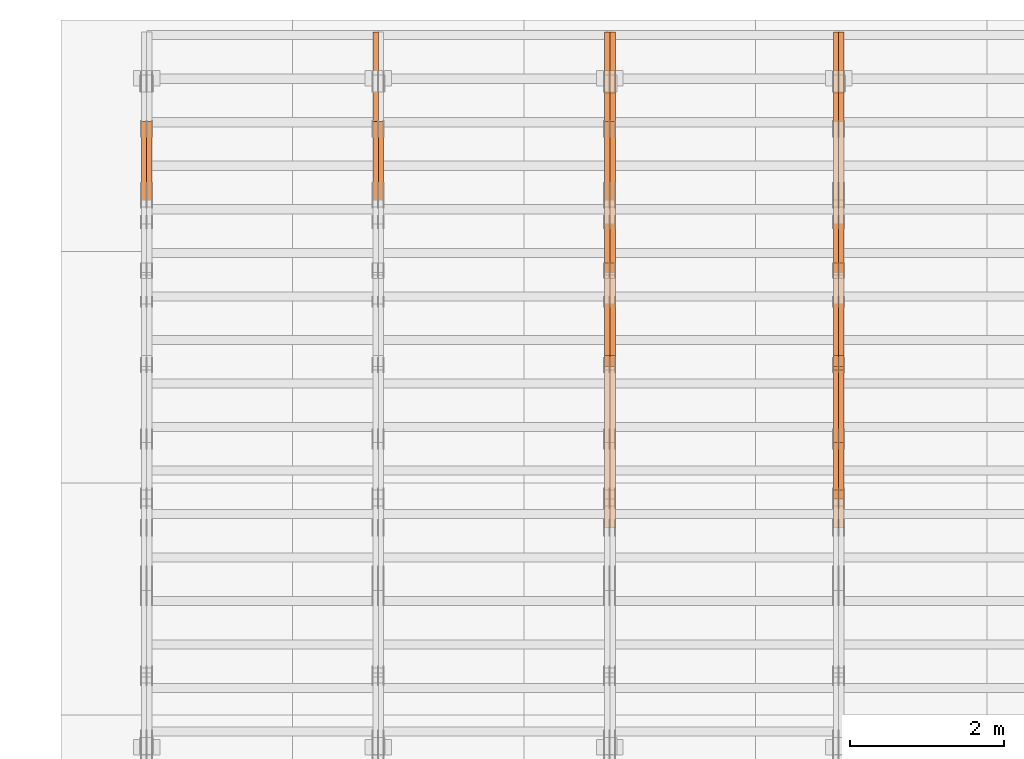
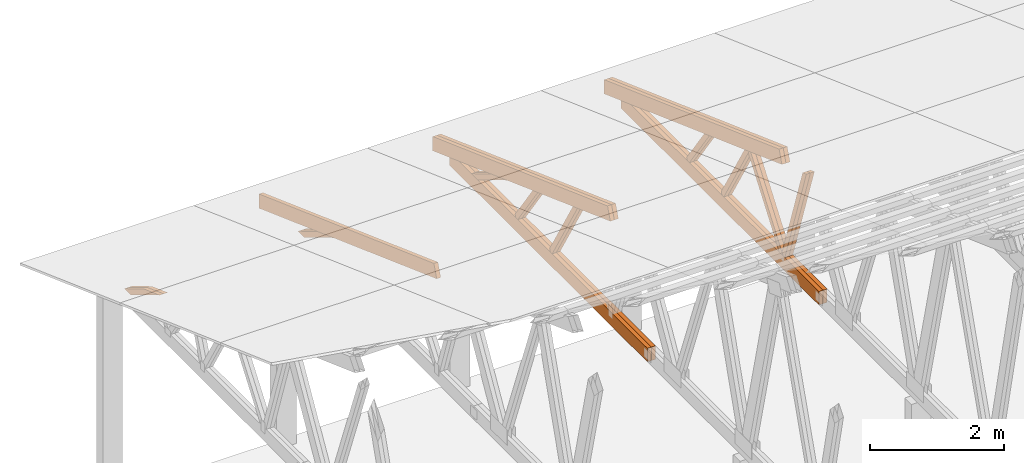
# One storey, part 36 of 189: 27 proxies.
"""IFC2X3 building model written with IfcOpenShell, lengths in millimetres."""

from ifc_helpers import new_model, entity, si_unit, converted_unit, derived_unit, direction, frame, origin, place, context, subcontext, project, spatial, polyline, outline, extrude, source, transform, mapped, material, type_object, type_shapes, element, save


model = new_model("IFC2X3")

# Units and contexts
model_context = context("Model", 3, precision=0.01, world=origin(), true_north=direction((6.12303176911189e-17, 1.0)))
body_context = subcontext(model_context, "Body", "Model", "MODEL_VIEW")
ifc_project = project(units=[si_unit("LENGTHUNIT", "METRE", prefix="MILLI"), si_unit("AREAUNIT", "SQUARE_METRE"), si_unit("VOLUMEUNIT", "CUBIC_METRE"), converted_unit("PLANEANGLEUNIT", "DEGREE", entity("IfcRatioMeasure", 0.0174532925199433), si_unit("PLANEANGLEUNIT", "RADIAN"), dimensions=[0, 0, 0, 0, 0, 0, 0]), si_unit("MASSUNIT", "GRAM", prefix="KILO"), derived_unit("MASSDENSITYUNIT", [(si_unit("MASSUNIT", "GRAM", prefix="KILO"), 1), (si_unit("LENGTHUNIT", "METRE"), -3)]), si_unit("TIMEUNIT", "SECOND"), si_unit("FREQUENCYUNIT", "HERTZ"), si_unit("THERMODYNAMICTEMPERATUREUNIT", "DEGREE_CELSIUS"), derived_unit("THERMALTRANSMITTANCEUNIT", [(si_unit("MASSUNIT", "GRAM", prefix="KILO"), 1), (si_unit("THERMODYNAMICTEMPERATUREUNIT", "KELVIN"), -1), (si_unit("TIMEUNIT", "SECOND"), -3)]), derived_unit("VOLUMETRICFLOWRATEUNIT", [(si_unit("LENGTHUNIT", "METRE"), 3), (si_unit("TIMEUNIT", "SECOND"), -1)]), si_unit("ELECTRICCURRENTUNIT", "AMPERE"), si_unit("ELECTRICVOLTAGEUNIT", "VOLT"), si_unit("POWERUNIT", "WATT"), si_unit("FORCEUNIT", "NEWTON"), si_unit("ILLUMINANCEUNIT", "LUX"), si_unit("LUMINOUSFLUXUNIT", "LUMEN"), si_unit("LUMINOUSINTENSITYUNIT", "CANDELA"), derived_unit("USERDEFINED", [(si_unit("MASSUNIT", "GRAM", prefix="KILO"), -1), (si_unit("LENGTHUNIT", "METRE"), -2), (si_unit("TIMEUNIT", "SECOND"), 3), (si_unit("LUMINOUSFLUXUNIT", "LUMEN"), 1)]), derived_unit("LINEARVELOCITYUNIT", [(si_unit("LENGTHUNIT", "METRE"), 1), (si_unit("TIMEUNIT", "SECOND"), -1)]), si_unit("PRESSUREUNIT", "PASCAL"), derived_unit("USERDEFINED", [(si_unit("LENGTHUNIT", "METRE"), -2), (si_unit("MASSUNIT", "GRAM", prefix="KILO"), 1), (si_unit("TIMEUNIT", "SECOND"), -2)])], contexts=[model_context])

# Site, building, storey
site_placement = place(None, origin())
site = spatial("IfcSite", under=ifc_project, at=site_placement, CompositionType="ELEMENT")
building_placement = place(site_placement, origin())
building = spatial("IfcBuilding", under=site, at=building_placement, CompositionType="ELEMENT")
storey_placement = place(building_placement, origin())
storey = spatial("IfcBuildingStorey", under=building, at=storey_placement, Name="Default", CompositionType="ELEMENT", Elevation=0.0)

# Proxies
ifc_material_1 = material(Name="IfcSurfaceStyle #50600")
building_element_proxy_type_1 = type_object("IfcBuildingElementProxyType", Name="T1-W9 50598", PredefinedType="NOTDEFINED", material=ifc_material_1)
shared_shape_1 = source(origin(), body_context, "Body", "SweptSolid", [
    extrude(outline(polyline([(-1151.44310138162, -47.5000079487596), (776.329826327547, -47.5000079487596), (809.267611644053, -8.1966354137375e-07), (793.242530238244, 47.5000083585914), (-1227.39686682822, 47.5000083585914), (-1151.44310138162, -47.5000079487596)])), frame((809.267685789073, 47.5000083585914, 0.0), z_axis=(0.0, 0.0, 1.0), x_axis=(-1.0, 0.0, 0.0)), (0.0, 0.0, 1.0), 69.9999999999999),
])
type_shapes(building_element_proxy_type_1, [shared_shape_1])
proxy_1_placement = place(building_placement, frame((9300.0, 24600.2198992919, 229.815691184017), z_axis=(-1.0, 0.0, 0.0), x_axis=(0.0, -0.31966811847134, 0.947529574226047)))
element("IfcBuildingElementProxy", 1, at=proxy_1_placement, inside=storey, type_object=building_element_proxy_type_1, material=ifc_material_1, Name="T1-W9", context=body_context, shape_type="MappedRepresentation", body=[
    mapped(shared_shape_1, transform((0.0, 0.0, 0.0), scale=1.0)),
])
ifc_material_2 = material(Name="IfcSurfaceStyle #50534")
building_element_proxy_type_2 = type_object("IfcBuildingElementProxyType", Name="T1-W9 50532", PredefinedType="NOTDEFINED", material=ifc_material_2)
shared_shape_2 = source(origin(), body_context, "Body", "SweptSolid", [
    extrude(outline(polyline([(-1151.44310138162, -47.5000079487596), (776.329826327547, -47.5000079487596), (809.267611644053, -8.1966354137375e-07), (793.242530238244, 47.5000083585914), (-1227.39686682822, 47.5000083585914), (-1151.44310138162, -47.5000079487596)])), frame((809.267685789073, 47.5000083585914, 0.0), z_axis=(0.0, 0.0, 1.0), x_axis=(-1.0, 0.0, 0.0)), (0.0, 0.0, 1.0), 69.9999999999999),
])
type_shapes(building_element_proxy_type_2, [shared_shape_2])
proxy_2_placement = place(building_placement, frame((9230.0, 24600.2198992919, 229.815691184017), z_axis=(-1.0, 0.0, 0.0), x_axis=(0.0, -0.31966811847134, 0.947529574226047)))
element("IfcBuildingElementProxy", 2, at=proxy_2_placement, inside=storey, type_object=building_element_proxy_type_2, material=ifc_material_2, Name="T1-W9", context=body_context, shape_type="MappedRepresentation", body=[
    mapped(shared_shape_2, transform((0.0, 0.0, 0.0), scale=1.0)),
])
ifc_material_3 = material(Name="IfcSurfaceStyle #50336")
building_element_proxy_type_3 = type_object("IfcBuildingElementProxyType", Name="T1-W10 50334", PredefinedType="NOTDEFINED", material=ifc_material_3)
shared_shape_3 = source(origin(), body_context, "Body", "SweptSolid", [
    extrude(outline(polyline([(-993.240970354386, -47.5000757607337), (635.890952815036, -47.5000757607337), (650.068145237537, -1.47580554758164e-05), (629.921374092803, 47.5000831397614), (-922.639501790989, 47.5000831397614), (-993.240970354386, -47.5000757607337)])), frame((650.068173419645, 47.5002811208496, 0.0), z_axis=(0.0, 0.0, 1.0), x_axis=(-1.0, 0.0, 0.0)), (0.0, 0.0, 1.0), 69.9999999999999),
])
type_shapes(building_element_proxy_type_3, [shared_shape_3])
proxy_3_placement = place(building_placement, frame((9300.0, 25701.688098798, 1507.2920009025), z_axis=(-1.0, 0.0, 0.0), x_axis=(0.0, -0.596486092002004, -0.802623412347395)))
element("IfcBuildingElementProxy", 3, at=proxy_3_placement, inside=storey, type_object=building_element_proxy_type_3, material=ifc_material_3, Name="T1-W10", context=body_context, shape_type="MappedRepresentation", body=[
    mapped(shared_shape_3, transform((0.0, 0.0, 0.0), scale=1.0)),
])
ifc_material_4 = material(Name="IfcSurfaceStyle #50270")
building_element_proxy_type_4 = type_object("IfcBuildingElementProxyType", Name="T1-W10 50268", PredefinedType="NOTDEFINED", material=ifc_material_4)
shared_shape_4 = source(origin(), body_context, "Body", "SweptSolid", [
    extrude(outline(polyline([(-993.240970354386, -47.5000757607337), (635.890952815036, -47.5000757607337), (650.068145237537, -1.47580554758164e-05), (629.921374092803, 47.5000831397614), (-922.639501790989, 47.5000831397614), (-993.240970354386, -47.5000757607337)])), frame((650.068173419645, 47.5002811208496, 0.0), z_axis=(0.0, 0.0, 1.0), x_axis=(-1.0, 0.0, 0.0)), (0.0, 0.0, 1.0), 69.9999999999999),
])
type_shapes(building_element_proxy_type_4, [shared_shape_4])
proxy_4_placement = place(building_placement, frame((9230.0, 25701.688098798, 1507.2920009025), z_axis=(-1.0, 0.0, 0.0), x_axis=(0.0, -0.596486092002004, -0.802623412347395)))
element("IfcBuildingElementProxy", 4, at=proxy_4_placement, inside=storey, type_object=building_element_proxy_type_4, material=ifc_material_4, Name="T1-W10", context=body_context, shape_type="MappedRepresentation", body=[
    mapped(shared_shape_4, transform((0.0, 0.0, 0.0), scale=1.0)),
])
ifc_material_5 = material(Name="IfcSurfaceStyle #50072")
building_element_proxy_type_5 = type_object("IfcBuildingElementProxyType", Name="T1-W11 50070", PredefinedType="NOTDEFINED", material=ifc_material_5)
shared_shape_5 = source(origin(), body_context, "Body", "SweptSolid", [
    extrude(outline(polyline([(-809.410890003667, -47.5000077306544), (561.624013869753, -47.5000077306544), (599.944137054867, -7.52294285037536e-05), (572.078784657538, 47.5000453453687), (-924.236045578491, 47.5000453453687), (-809.410890003667, -47.5000077306544)])), frame((599.944137054867, 47.5000453453687, 0.0), z_axis=(0.0, 0.0, 1.0), x_axis=(-1.0, 0.0, 0.0)), (0.0, 0.0, 1.0), 69.9999999999999),
])
type_shapes(building_element_proxy_type_5, [shared_shape_5])
proxy_5_placement = place(building_placement, frame((9300.0, 26434.7921369083, 220.965133687368), z_axis=(-1.0, 0.0, 0.0), x_axis=(0.0, -0.505995901100603, 0.862535882192381)))
element("IfcBuildingElementProxy", 5, at=proxy_5_placement, inside=storey, type_object=building_element_proxy_type_5, material=ifc_material_5, Name="T1-W11", context=body_context, shape_type="MappedRepresentation", body=[
    mapped(shared_shape_5, transform((0.0, 0.0, 0.0), scale=1.0)),
])
ifc_material_6 = material(Name="IfcSurfaceStyle #50006")
building_element_proxy_type_6 = type_object("IfcBuildingElementProxyType", Name="T1-W11 50004", PredefinedType="NOTDEFINED", material=ifc_material_6)
shared_shape_6 = source(origin(), body_context, "Body", "SweptSolid", [
    extrude(outline(polyline([(-809.410890003667, -47.5000077306544), (561.624013869753, -47.5000077306544), (599.944137054867, -7.52294285037536e-05), (572.078784657538, 47.5000453453687), (-924.236045578491, 47.5000453453687), (-809.410890003667, -47.5000077306544)])), frame((599.944137054867, 47.5000453453687, 0.0), z_axis=(0.0, 0.0, 1.0), x_axis=(-1.0, 0.0, 0.0)), (0.0, 0.0, 1.0), 69.9999999999999),
])
type_shapes(building_element_proxy_type_6, [shared_shape_6])
proxy_6_placement = place(building_placement, frame((9230.0, 26434.7921369083, 220.965133687368), z_axis=(-1.0, 0.0, 0.0), x_axis=(0.0, -0.505995901100603, 0.862535882192381)))
element("IfcBuildingElementProxy", 6, at=proxy_6_placement, inside=storey, type_object=building_element_proxy_type_6, material=ifc_material_6, Name="T1-W11", context=body_context, shape_type="MappedRepresentation", body=[
    mapped(shared_shape_6, transform((0.0, 0.0, 0.0), scale=1.0)),
])
ifc_material_7 = material(Name="IfcSurfaceStyle #49544")
building_element_proxy_type_7 = type_object("IfcBuildingElementProxyType", Name="T1-W13 49542", PredefinedType="NOTDEFINED", material=ifc_material_7)
shared_shape_7 = source(origin(), body_context, "Body", "SweptSolid", [
    extrude(outline(polyline([(-527.416466728212, -47.5000272833949), (387.658053197984, -47.5000272833949), (418.029495084182, -7.96824534414764e-06), (384.779443025059, 47.5000312675175), (-663.050524579013, 47.5000312675176), (-527.416466728212, -47.5000272833949)])), frame((418.029495084182, 47.5000671658844, 0.0), z_axis=(0.0, 0.0, 1.0), x_axis=(-1.0, 0.0, 0.0)), (0.0, 0.0, 1.0), 69.9999999999999),
])
type_shapes(building_element_proxy_type_7, [shared_shape_7])
proxy_7_placement = place(building_placement, frame((9300.0, 27471.0085508293, 217.760482033818), z_axis=(-1.0, 0.0, 0.0), x_axis=(0.0, -0.573462629043498, 0.819231721242848)))
element("IfcBuildingElementProxy", 7, at=proxy_7_placement, inside=storey, type_object=building_element_proxy_type_7, material=ifc_material_7, Name="T1-W13", context=body_context, shape_type="MappedRepresentation", body=[
    mapped(shared_shape_7, transform((0.0, 0.0, 0.0), scale=1.0)),
])
ifc_material_8 = material(Name="IfcSurfaceStyle #49478")
building_element_proxy_type_8 = type_object("IfcBuildingElementProxyType", Name="T1-W13 49476", PredefinedType="NOTDEFINED", material=ifc_material_8)
shared_shape_8 = source(origin(), body_context, "Body", "SweptSolid", [
    extrude(outline(polyline([(-527.416466728212, -47.5000272833949), (387.658053197984, -47.5000272833949), (418.029495084182, -7.96824534414764e-06), (384.779443025059, 47.5000312675175), (-663.050524579013, 47.5000312675176), (-527.416466728212, -47.5000272833949)])), frame((418.029495084182, 47.5000671658844, 0.0), z_axis=(0.0, 0.0, 1.0), x_axis=(-1.0, 0.0, 0.0)), (0.0, 0.0, 1.0), 69.9999999999999),
])
type_shapes(building_element_proxy_type_8, [shared_shape_8])
proxy_8_placement = place(building_placement, frame((9230.0, 27471.0085508293, 217.760482033818), z_axis=(-1.0, 0.0, 0.0), x_axis=(0.0, -0.573462629043498, 0.819231721242848)))
element("IfcBuildingElementProxy", 8, at=proxy_8_placement, inside=storey, type_object=building_element_proxy_type_8, material=ifc_material_8, Name="T1-W13", context=body_context, shape_type="MappedRepresentation", body=[
    mapped(shared_shape_8, transform((0.0, 0.0, 0.0), scale=1.0)),
])
ifc_material_9 = material(Name="IfcSurfaceStyle #48920")
building_element_proxy_type_9 = type_object("IfcBuildingElementProxyType", Name="T1-B1 48918", PredefinedType="NOTDEFINED", material=ifc_material_9)
shared_shape_9 = source(origin(), body_context, "Body", "SweptSolid", [
    extrude(outline(polyline([(-2430.09461669922, -125.855288696288), (3499.90538330078, -125.855288696288), (3499.90538330078, 119.144711303711), (-2139.62153320312, 119.144711303711), (-2430.09461669922, 13.4211547851552), (-2430.09461669922, -125.855288696288)])), frame((3499.90538330078, 119.144711303711, 0.0), z_axis=(0.0, 0.0, 1.0), x_axis=(-1.0, 0.0, 0.0)), (0.0, 0.0, 1.0), 69.9999999999996),
])
type_shapes(building_element_proxy_type_9, [shared_shape_9])
proxy_9_placement = place(building_placement, frame((9300.0, 23570.0, 245.0), z_axis=(-1.0, 0.0, 0.0), x_axis=(0.0, 1.0, 0.0)))
element("IfcBuildingElementProxy", 9, at=proxy_9_placement, inside=storey, type_object=building_element_proxy_type_9, material=ifc_material_9, Name="T1-B1", context=body_context, shape_type="MappedRepresentation", body=[
    mapped(shared_shape_9, transform((0.0, 0.0, 0.0), scale=1.0)),
])
ifc_material_10 = material(Name="IfcSurfaceStyle #48854")
building_element_proxy_type_10 = type_object("IfcBuildingElementProxyType", Name="T1-B1 48852", PredefinedType="NOTDEFINED", material=ifc_material_10)
shared_shape_10 = source(origin(), body_context, "Body", "SweptSolid", [
    extrude(outline(polyline([(-2430.09461669922, -125.855288696288), (3499.90538330078, -125.855288696288), (3499.90538330078, 119.144711303711), (-2139.62153320312, 119.144711303711), (-2430.09461669922, 13.4211547851552), (-2430.09461669922, -125.855288696288)])), frame((3499.90538330078, 119.144711303711, 0.0), z_axis=(0.0, 0.0, 1.0), x_axis=(-1.0, 0.0, 0.0)), (0.0, 0.0, 1.0), 69.9999999999996),
])
type_shapes(building_element_proxy_type_10, [shared_shape_10])
proxy_10_placement = place(building_placement, frame((9230.0, 23570.0, 245.0), z_axis=(-1.0, 0.0, 0.0), x_axis=(0.0, 1.0, 0.0)))
element("IfcBuildingElementProxy", 10, at=proxy_10_placement, inside=storey, type_object=building_element_proxy_type_10, material=ifc_material_10, Name="T1-B1", context=body_context, shape_type="MappedRepresentation", body=[
    mapped(shared_shape_10, transform((0.0, 0.0, 0.0), scale=1.0)),
])
ifc_material_11 = material(Name="IfcSurfaceStyle #47630")
building_element_proxy_type_11 = type_object("IfcBuildingElementProxyType", Name="T1-T2 47628", PredefinedType="NOTDEFINED", material=ifc_material_11)
shared_shape_11 = source(origin(), body_context, "Body", "SweptSolid", [
    extrude(outline(polyline([(-2807.70681121203, -122.500041939424), (2763.12044548192, -122.500041939424), (2852.29315104137, 122.500041939424), (-2807.70678531126, 122.500041939424), (-2807.70681121203, -122.500041939424)])), frame((2852.29315104137, 122.500041939424, 0.0), z_axis=(0.0, 0.0, 1.0), x_axis=(-1.0, 0.0, 0.0)), (0.0, 0.0, 1.0), 69.9999999999997),
])
type_shapes(building_element_proxy_type_11, [shared_shape_11])
proxy_11_placement = place(building_placement, frame((9300.0, 30000.0, -42.7086715698242), z_axis=(-1.0, 0.0, 0.0), x_axis=(0.0, -0.939692620785908, 0.342020143325669)))
element("IfcBuildingElementProxy", 11, at=proxy_11_placement, inside=storey, type_object=building_element_proxy_type_11, material=ifc_material_11, Name="T1-T2", context=body_context, shape_type="MappedRepresentation", body=[
    mapped(shared_shape_11, transform((0.0, 0.0, 0.0), scale=1.0)),
])
ifc_material_12 = material(Name="IfcSurfaceStyle #47573")
building_element_proxy_type_12 = type_object("IfcBuildingElementProxyType", Name="T1-T2 47571", PredefinedType="NOTDEFINED", material=ifc_material_12)
shared_shape_12 = source(origin(), body_context, "Body", "SweptSolid", [
    extrude(outline(polyline([(-2807.70681121203, -122.500041939424), (2763.12044548192, -122.500041939424), (2852.29315104137, 122.500041939424), (-2807.70678531126, 122.500041939424), (-2807.70681121203, -122.500041939424)])), frame((2852.29315104137, 122.500041939424, 0.0), z_axis=(0.0, 0.0, 1.0), x_axis=(-1.0, 0.0, 0.0)), (0.0, 0.0, 1.0), 69.9999999999997),
])
type_shapes(building_element_proxy_type_12, [shared_shape_12])
proxy_12_placement = place(building_placement, frame((9230.0, 30000.0, -42.7086715698242), z_axis=(-1.0, 0.0, 0.0), x_axis=(0.0, -0.939692620785908, 0.342020143325669)))
element("IfcBuildingElementProxy", 12, at=proxy_12_placement, inside=storey, type_object=building_element_proxy_type_12, material=ifc_material_12, Name="T1-T2", context=body_context, shape_type="MappedRepresentation", body=[
    mapped(shared_shape_12, transform((0.0, 0.0, 0.0), scale=1.0)),
])
ifc_material_13 = material(Name="IfcSurfaceStyle #34282")
building_element_proxy_type_13 = type_object("IfcBuildingElementProxyType", Name="T1-W11 34280", PredefinedType="NOTDEFINED", material=ifc_material_13)
shared_shape_13 = source(origin(), body_context, "Body", "SweptSolid", [
    extrude(outline(polyline([(-809.410890003667, -47.5000077306544), (561.624013869753, -47.5000077306544), (599.944137054867, -7.52294285037536e-05), (572.078784657538, 47.5000453453687), (-924.236045578491, 47.5000453453687), (-809.410890003667, -47.5000077306544)])), frame((599.944137054867, 47.5000453453687, 0.0), z_axis=(0.0, 0.0, 1.0), x_axis=(-1.0, 0.0, 0.0)), (0.0, 0.0, 1.0), 69.9999999999999),
])
type_shapes(building_element_proxy_type_13, [shared_shape_13])
proxy_13_placement = place(building_placement, frame((6335.0, 26434.7921369083, 220.965133687368), z_axis=(-1.0, 0.0, 0.0), x_axis=(0.0, -0.505995901100603, 0.862535882192381)))
element("IfcBuildingElementProxy", 13, at=proxy_13_placement, inside=storey, type_object=building_element_proxy_type_13, material=ifc_material_13, Name="T1-W11", context=body_context, shape_type="MappedRepresentation", body=[
    mapped(shared_shape_13, transform((0.0, 0.0, 0.0), scale=1.0)),
])
ifc_material_14 = material(Name="IfcSurfaceStyle #34216")
building_element_proxy_type_14 = type_object("IfcBuildingElementProxyType", Name="T1-W11 34214", PredefinedType="NOTDEFINED", material=ifc_material_14)
shared_shape_14 = source(origin(), body_context, "Body", "SweptSolid", [
    extrude(outline(polyline([(-809.410890003667, -47.5000077306544), (561.624013869753, -47.5000077306544), (599.944137054867, -7.52294285037536e-05), (572.078784657538, 47.5000453453687), (-924.236045578491, 47.5000453453687), (-809.410890003667, -47.5000077306544)])), frame((599.944137054867, 47.5000453453687, 0.0), z_axis=(0.0, 0.0, 1.0), x_axis=(-1.0, 0.0, 0.0)), (0.0, 0.0, 1.0), 69.9999999999999),
])
type_shapes(building_element_proxy_type_14, [shared_shape_14])
proxy_14_placement = place(building_placement, frame((6265.0, 26434.7921369083, 220.965133687368), z_axis=(-1.0, 0.0, 0.0), x_axis=(0.0, -0.505995901100603, 0.862535882192381)))
element("IfcBuildingElementProxy", 14, at=proxy_14_placement, inside=storey, type_object=building_element_proxy_type_14, material=ifc_material_14, Name="T1-W11", context=body_context, shape_type="MappedRepresentation", body=[
    mapped(shared_shape_14, transform((0.0, 0.0, 0.0), scale=1.0)),
])
ifc_material_15 = material(Name="IfcSurfaceStyle #33754")
building_element_proxy_type_15 = type_object("IfcBuildingElementProxyType", Name="T1-W13 33752", PredefinedType="NOTDEFINED", material=ifc_material_15)
shared_shape_15 = source(origin(), body_context, "Body", "SweptSolid", [
    extrude(outline(polyline([(-527.416466728212, -47.5000272833949), (387.658053197984, -47.5000272833949), (418.029495084182, -7.96824534414764e-06), (384.779443025059, 47.5000312675175), (-663.050524579013, 47.5000312675176), (-527.416466728212, -47.5000272833949)])), frame((418.029495084182, 47.5000671658844, 0.0), z_axis=(0.0, 0.0, 1.0), x_axis=(-1.0, 0.0, 0.0)), (0.0, 0.0, 1.0), 69.9999999999999),
])
type_shapes(building_element_proxy_type_15, [shared_shape_15])
proxy_15_placement = place(building_placement, frame((6335.0, 27471.0085508293, 217.760482033818), z_axis=(-1.0, 0.0, 0.0), x_axis=(0.0, -0.573462629043498, 0.819231721242848)))
element("IfcBuildingElementProxy", 15, at=proxy_15_placement, inside=storey, type_object=building_element_proxy_type_15, material=ifc_material_15, Name="T1-W13", context=body_context, shape_type="MappedRepresentation", body=[
    mapped(shared_shape_15, transform((0.0, 0.0, 0.0), scale=1.0)),
])
ifc_material_16 = material(Name="IfcSurfaceStyle #33688")
building_element_proxy_type_16 = type_object("IfcBuildingElementProxyType", Name="T1-W13 33686", PredefinedType="NOTDEFINED", material=ifc_material_16)
shared_shape_16 = source(origin(), body_context, "Body", "SweptSolid", [
    extrude(outline(polyline([(-527.416466728212, -47.5000272833949), (387.658053197984, -47.5000272833949), (418.029495084182, -7.96824534414764e-06), (384.779443025059, 47.5000312675175), (-663.050524579013, 47.5000312675176), (-527.416466728212, -47.5000272833949)])), frame((418.029495084182, 47.5000671658844, 0.0), z_axis=(0.0, 0.0, 1.0), x_axis=(-1.0, 0.0, 0.0)), (0.0, 0.0, 1.0), 69.9999999999999),
])
type_shapes(building_element_proxy_type_16, [shared_shape_16])
proxy_16_placement = place(building_placement, frame((6265.0, 27471.0085508293, 217.760482033818), z_axis=(-1.0, 0.0, 0.0), x_axis=(0.0, -0.573462629043498, 0.819231721242848)))
element("IfcBuildingElementProxy", 16, at=proxy_16_placement, inside=storey, type_object=building_element_proxy_type_16, material=ifc_material_16, Name="T1-W13", context=body_context, shape_type="MappedRepresentation", body=[
    mapped(shared_shape_16, transform((0.0, 0.0, 0.0), scale=1.0)),
])
ifc_material_17 = material(Name="IfcSurfaceStyle #33244")
building_element_proxy_type_17 = type_object("IfcBuildingElementProxyType", Name="T1-W12 33242", PredefinedType="NOTDEFINED", material=ifc_material_17)
shared_shape_17 = source(origin(), body_context, "Body", "SweptSolid", [
    extrude(outline(polyline([(-176.861423449428, -47.5000064161489), (503.856777435794, -47.5000064161489), (344.893496040196, 47.5000064161489), (-671.888850026563, 47.5000064161488), (-176.861423449428, -47.5000064161489)])), frame((503.856799890979, 47.5000428456028, 0.0), z_axis=(0.0, 0.0, 1.0), x_axis=(-1.0, 0.0, 0.0)), (0.0, 0.0, 1.0), 69.9999999999999),
])
type_shapes(building_element_proxy_type_17, [shared_shape_17])
proxy_17_placement = place(building_placement, frame((6335.0, 28785.6842742264, 163.452728724015), z_axis=(-1.0, 0.0, 0.0), x_axis=(0.0, -0.858392121304013, 0.51299411895576)))
element("IfcBuildingElementProxy", 17, at=proxy_17_placement, inside=storey, type_object=building_element_proxy_type_17, material=ifc_material_17, Name="T1-W12", context=body_context, shape_type="MappedRepresentation", body=[
    mapped(shared_shape_17, transform((0.0, 0.0, 0.0), scale=1.0)),
])
ifc_material_18 = material(Name="IfcSurfaceStyle #33187")
building_element_proxy_type_18 = type_object("IfcBuildingElementProxyType", Name="T1-W12 33185", PredefinedType="NOTDEFINED", material=ifc_material_18)
shared_shape_18 = source(origin(), body_context, "Body", "SweptSolid", [
    extrude(outline(polyline([(-176.861423449428, -47.5000064161489), (503.856777435794, -47.5000064161489), (344.893496040196, 47.5000064161489), (-671.888850026563, 47.5000064161488), (-176.861423449428, -47.5000064161489)])), frame((503.856799890979, 47.5000428456028, 0.0), z_axis=(0.0, 0.0, 1.0), x_axis=(-1.0, 0.0, 0.0)), (0.0, 0.0, 1.0), 69.9999999999999),
])
type_shapes(building_element_proxy_type_18, [shared_shape_18])
proxy_18_placement = place(building_placement, frame((6265.0, 28785.6842742264, 163.452728724015), z_axis=(-1.0, 0.0, 0.0), x_axis=(0.0, -0.858392121304013, 0.51299411895576)))
element("IfcBuildingElementProxy", 18, at=proxy_18_placement, inside=storey, type_object=building_element_proxy_type_18, material=ifc_material_18, Name="T1-W12", context=body_context, shape_type="MappedRepresentation", body=[
    mapped(shared_shape_18, transform((0.0, 0.0, 0.0), scale=1.0)),
])
ifc_material_19 = material(Name="IfcSurfaceStyle #33130")
building_element_proxy_type_19 = type_object("IfcBuildingElementProxyType", Name="T1-B1 33128", PredefinedType="NOTDEFINED", material=ifc_material_19)
shared_shape_19 = source(origin(), body_context, "Body", "SweptSolid", [
    extrude(outline(polyline([(-2430.09461669922, -125.855288696288), (3499.90538330078, -125.855288696288), (3499.90538330078, 119.144711303711), (-2139.62153320312, 119.144711303711), (-2430.09461669922, 13.4211547851552), (-2430.09461669922, -125.855288696288)])), frame((3499.90538330078, 119.144711303711, 0.0), z_axis=(0.0, 0.0, 1.0), x_axis=(-1.0, 0.0, 0.0)), (0.0, 0.0, 1.0), 69.9999999999996),
])
type_shapes(building_element_proxy_type_19, [shared_shape_19])
proxy_19_placement = place(building_placement, frame((6335.0, 23570.0, 245.0), z_axis=(-1.0, 0.0, 0.0), x_axis=(0.0, 1.0, 0.0)))
element("IfcBuildingElementProxy", 19, at=proxy_19_placement, inside=storey, type_object=building_element_proxy_type_19, material=ifc_material_19, Name="T1-B1", context=body_context, shape_type="MappedRepresentation", body=[
    mapped(shared_shape_19, transform((0.0, 0.0, 0.0), scale=1.0)),
])
ifc_material_20 = material(Name="IfcSurfaceStyle #33064")
building_element_proxy_type_20 = type_object("IfcBuildingElementProxyType", Name="T1-B1 33062", PredefinedType="NOTDEFINED", material=ifc_material_20)
shared_shape_20 = source(origin(), body_context, "Body", "SweptSolid", [
    extrude(outline(polyline([(-2430.09461669922, -125.855288696288), (3499.90538330078, -125.855288696288), (3499.90538330078, 119.144711303711), (-2139.62153320312, 119.144711303711), (-2430.09461669922, 13.4211547851552), (-2430.09461669922, -125.855288696288)])), frame((3499.90538330078, 119.144711303711, 0.0), z_axis=(0.0, 0.0, 1.0), x_axis=(-1.0, 0.0, 0.0)), (0.0, 0.0, 1.0), 69.9999999999996),
])
type_shapes(building_element_proxy_type_20, [shared_shape_20])
proxy_20_placement = place(building_placement, frame((6265.0, 23570.0, 245.0), z_axis=(-1.0, 0.0, 0.0), x_axis=(0.0, 1.0, 0.0)))
element("IfcBuildingElementProxy", 20, at=proxy_20_placement, inside=storey, type_object=building_element_proxy_type_20, material=ifc_material_20, Name="T1-B1", context=body_context, shape_type="MappedRepresentation", body=[
    mapped(shared_shape_20, transform((0.0, 0.0, 0.0), scale=1.0)),
])
ifc_material_21 = material(Name="IfcSurfaceStyle #31840")
building_element_proxy_type_21 = type_object("IfcBuildingElementProxyType", Name="T1-T2 31838", PredefinedType="NOTDEFINED", material=ifc_material_21)
shared_shape_21 = source(origin(), body_context, "Body", "SweptSolid", [
    extrude(outline(polyline([(-2807.70681121203, -122.500041939424), (2763.12044548192, -122.500041939424), (2852.29315104137, 122.500041939424), (-2807.70678531126, 122.500041939424), (-2807.70681121203, -122.500041939424)])), frame((2852.29315104137, 122.500041939424, 0.0), z_axis=(0.0, 0.0, 1.0), x_axis=(-1.0, 0.0, 0.0)), (0.0, 0.0, 1.0), 69.9999999999997),
])
type_shapes(building_element_proxy_type_21, [shared_shape_21])
proxy_21_placement = place(building_placement, frame((6335.0, 30000.0, -42.7086715698242), z_axis=(-1.0, 0.0, 0.0), x_axis=(0.0, -0.939692620785908, 0.342020143325669)))
element("IfcBuildingElementProxy", 21, at=proxy_21_placement, inside=storey, type_object=building_element_proxy_type_21, material=ifc_material_21, Name="T1-T2", context=body_context, shape_type="MappedRepresentation", body=[
    mapped(shared_shape_21, transform((0.0, 0.0, 0.0), scale=1.0)),
])
ifc_material_22 = material(Name="IfcSurfaceStyle #31783")
building_element_proxy_type_22 = type_object("IfcBuildingElementProxyType", Name="T1-T2 31781", PredefinedType="NOTDEFINED", material=ifc_material_22)
shared_shape_22 = source(origin(), body_context, "Body", "SweptSolid", [
    extrude(outline(polyline([(-2807.70681121203, -122.500041939424), (2763.12044548192, -122.500041939424), (2852.29315104137, 122.500041939424), (-2807.70678531126, 122.500041939424), (-2807.70681121203, -122.500041939424)])), frame((2852.29315104137, 122.500041939424, 0.0), z_axis=(0.0, 0.0, 1.0), x_axis=(-1.0, 0.0, 0.0)), (0.0, 0.0, 1.0), 69.9999999999997),
])
type_shapes(building_element_proxy_type_22, [shared_shape_22])
proxy_22_placement = place(building_placement, frame((6265.0, 30000.0, -42.7086715698242), z_axis=(-1.0, 0.0, 0.0), x_axis=(0.0, -0.939692620785908, 0.342020143325669)))
element("IfcBuildingElementProxy", 22, at=proxy_22_placement, inside=storey, type_object=building_element_proxy_type_22, material=ifc_material_22, Name="T1-T2", context=body_context, shape_type="MappedRepresentation", body=[
    mapped(shared_shape_22, transform((0.0, 0.0, 0.0), scale=1.0)),
])
ifc_material_23 = material(Name="IfcSurfaceStyle #17454")
building_element_proxy_type_23 = type_object("IfcBuildingElementProxyType", Name="T1-W12 17452", PredefinedType="NOTDEFINED", material=ifc_material_23)
shared_shape_23 = source(origin(), body_context, "Body", "SweptSolid", [
    extrude(outline(polyline([(-176.861423449428, -47.5000064161489), (503.856777435794, -47.5000064161489), (344.893496040196, 47.5000064161489), (-671.888850026563, 47.5000064161488), (-176.861423449428, -47.5000064161489)])), frame((503.856799890979, 47.5000428456028, 0.0), z_axis=(0.0, 0.0, 1.0), x_axis=(-1.0, 0.0, 0.0)), (0.0, 0.0, 1.0), 69.9999999999999),
])
type_shapes(building_element_proxy_type_23, [shared_shape_23])
proxy_23_placement = place(building_placement, frame((3335.0, 28785.6842742264, 163.452728724015), z_axis=(-1.0, 0.0, 0.0), x_axis=(0.0, -0.858392121304013, 0.51299411895576)))
element("IfcBuildingElementProxy", 23, at=proxy_23_placement, inside=storey, type_object=building_element_proxy_type_23, material=ifc_material_23, Name="T1-W12", context=body_context, shape_type="MappedRepresentation", body=[
    mapped(shared_shape_23, transform((0.0, 0.0, 0.0), scale=1.0)),
])
ifc_material_24 = material(Name="IfcSurfaceStyle #17397")
building_element_proxy_type_24 = type_object("IfcBuildingElementProxyType", Name="T1-W12 17395", PredefinedType="NOTDEFINED", material=ifc_material_24)
shared_shape_24 = source(origin(), body_context, "Body", "SweptSolid", [
    extrude(outline(polyline([(-176.861423449428, -47.5000064161489), (503.856777435794, -47.5000064161489), (344.893496040196, 47.5000064161489), (-671.888850026563, 47.5000064161488), (-176.861423449428, -47.5000064161489)])), frame((503.856799890979, 47.5000428456028, 0.0), z_axis=(0.0, 0.0, 1.0), x_axis=(-1.0, 0.0, 0.0)), (0.0, 0.0, 1.0), 69.9999999999999),
])
type_shapes(building_element_proxy_type_24, [shared_shape_24])
proxy_24_placement = place(building_placement, frame((3265.0, 28785.6842742264, 163.452728724015), z_axis=(-1.0, 0.0, 0.0), x_axis=(0.0, -0.858392121304013, 0.51299411895576)))
element("IfcBuildingElementProxy", 24, at=proxy_24_placement, inside=storey, type_object=building_element_proxy_type_24, material=ifc_material_24, Name="T1-W12", context=body_context, shape_type="MappedRepresentation", body=[
    mapped(shared_shape_24, transform((0.0, 0.0, 0.0), scale=1.0)),
])
ifc_material_25 = material(Name="IfcSurfaceStyle #15993")
building_element_proxy_type_25 = type_object("IfcBuildingElementProxyType", Name="T1-T2 15991", PredefinedType="NOTDEFINED", material=ifc_material_25)
shared_shape_25 = source(origin(), body_context, "Body", "SweptSolid", [
    extrude(outline(polyline([(-2807.70681121203, -122.500041939424), (2763.12044548192, -122.500041939424), (2852.29315104137, 122.500041939424), (-2807.70678531126, 122.500041939424), (-2807.70681121203, -122.500041939424)])), frame((2852.29315104137, 122.500041939424, 0.0), z_axis=(0.0, 0.0, 1.0), x_axis=(-1.0, 0.0, 0.0)), (0.0, 0.0, 1.0), 69.9999999999997),
])
type_shapes(building_element_proxy_type_25, [shared_shape_25])
proxy_25_placement = place(building_placement, frame((3265.0, 30000.0, -42.7086715698242), z_axis=(-1.0, 0.0, 0.0), x_axis=(0.0, -0.939692620785908, 0.342020143325669)))
element("IfcBuildingElementProxy", 25, at=proxy_25_placement, inside=storey, type_object=building_element_proxy_type_25, material=ifc_material_25, Name="T1-T2", context=body_context, shape_type="MappedRepresentation", body=[
    mapped(shared_shape_25, transform((0.0, 0.0, 0.0), scale=1.0)),
])
ifc_material_26 = material(Name="IfcSurfaceStyle #1661")
building_element_proxy_type_26 = type_object("IfcBuildingElementProxyType", Name="T1-W12 1659", PredefinedType="NOTDEFINED", material=ifc_material_26)
shared_shape_26 = source(origin(), body_context, "Body", "SweptSolid", [
    extrude(outline(polyline([(-176.861423449428, -47.5000064161489), (503.856777435794, -47.5000064161489), (344.893496040196, 47.5000064161489), (-671.888850026563, 47.5000064161488), (-176.861423449428, -47.5000064161489)])), frame((503.856799890979, 47.5000428456028, 0.0), z_axis=(0.0, 0.0, 1.0), x_axis=(-1.0, 0.0, 0.0)), (0.0, 0.0, 1.0), 69.9999999999999),
])
type_shapes(building_element_proxy_type_26, [shared_shape_26])
proxy_26_placement = place(building_placement, frame((335.0, 28785.6842742264, 163.452728724015), z_axis=(-1.0, 0.0, 0.0), x_axis=(0.0, -0.858392121304013, 0.51299411895576)))
element("IfcBuildingElementProxy", 26, at=proxy_26_placement, inside=storey, type_object=building_element_proxy_type_26, material=ifc_material_26, Name="T1-W12", context=body_context, shape_type="MappedRepresentation", body=[
    mapped(shared_shape_26, transform((0.0, 0.0, 0.0), scale=1.0)),
])
ifc_material_27 = material(Name="IfcSurfaceStyle #1604")
building_element_proxy_type_27 = type_object("IfcBuildingElementProxyType", Name="T1-W12 1602", PredefinedType="NOTDEFINED", material=ifc_material_27)
shared_shape_27 = source(origin(), body_context, "Body", "SweptSolid", [
    extrude(outline(polyline([(-176.861423449428, -47.5000064161489), (503.856777435794, -47.5000064161489), (344.893496040196, 47.5000064161489), (-671.888850026563, 47.5000064161488), (-176.861423449428, -47.5000064161489)])), frame((503.856799890979, 47.5000428456028, 0.0), z_axis=(0.0, 0.0, 1.0), x_axis=(-1.0, 0.0, 0.0)), (0.0, 0.0, 1.0), 69.9999999999999),
])
type_shapes(building_element_proxy_type_27, [shared_shape_27])
proxy_27_placement = place(building_placement, frame((265.0, 28785.6842742264, 163.452728724015), z_axis=(-1.0, 0.0, 0.0), x_axis=(0.0, -0.858392121304013, 0.51299411895576)))
element("IfcBuildingElementProxy", 27, at=proxy_27_placement, inside=storey, type_object=building_element_proxy_type_27, material=ifc_material_27, Name="T1-W12", context=body_context, shape_type="MappedRepresentation", body=[
    mapped(shared_shape_27, transform((0.0, 0.0, 0.0), scale=1.0)),
])

save(model, "model.ifc")
